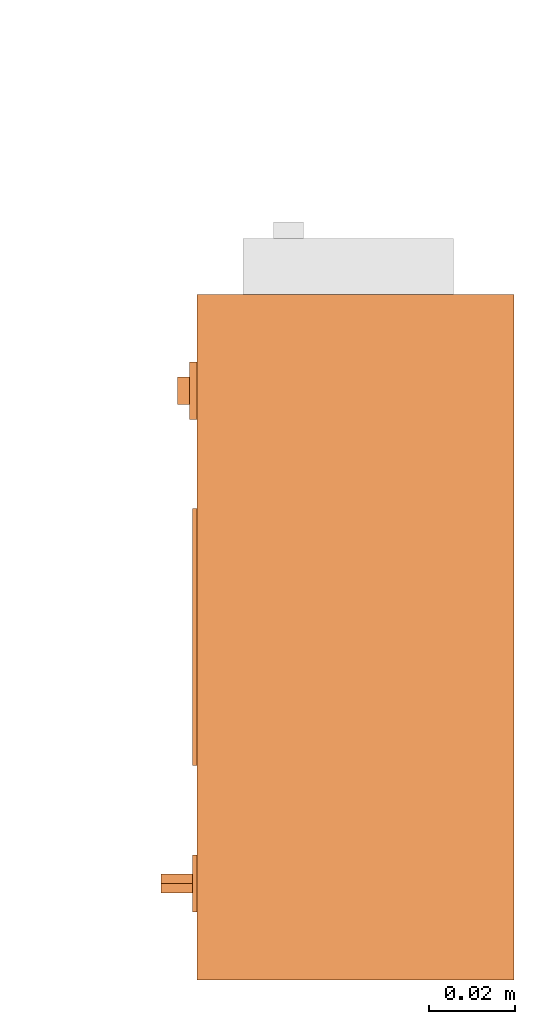
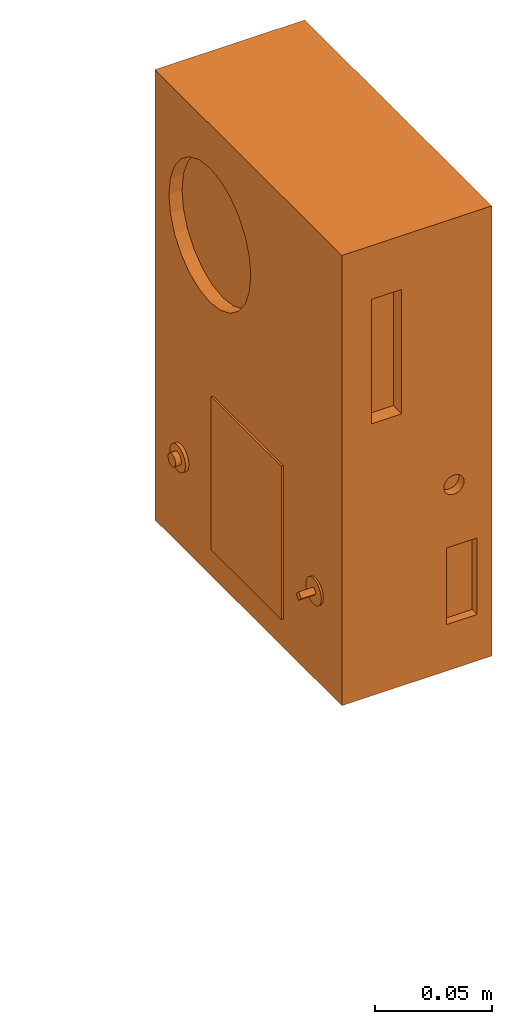
# One storey, part 2 of 4: 1 proxy.
"""IFC2X3 building model written with IfcOpenShell, lengths in millimetres."""

from ifc_helpers import new_model, entity, si_unit, converted_unit, derived_unit, direction, frame, origin, place, context, subcontext, project, spatial, faceted_brep, source, transform, mapped, material, material_list, type_object, type_shapes, element, save


model = new_model("IFC2X3")

# Units and contexts
model_context = context("Model", 3, precision=0.01, world=origin(), true_north=direction((6.12303176911189e-17, 1.0)))
body_context = subcontext(model_context, "Body", "Model", "MODEL_VIEW")
ifc_project = project(units=[si_unit("LENGTHUNIT", "METRE", prefix="MILLI"), si_unit("AREAUNIT", "SQUARE_METRE"), si_unit("VOLUMEUNIT", "CUBIC_METRE"), converted_unit("PLANEANGLEUNIT", "DEGREE", entity("IfcRatioMeasure", 0.0174532925199433), si_unit("PLANEANGLEUNIT", "RADIAN"), dimensions=[0, 0, 0, 0, 0, 0, 0]), si_unit("MASSUNIT", "GRAM", prefix="KILO"), derived_unit("MASSDENSITYUNIT", [(si_unit("MASSUNIT", "GRAM", prefix="KILO"), 1), (si_unit("LENGTHUNIT", "METRE"), -3)]), derived_unit("MOMENTOFINERTIAUNIT", [(si_unit("LENGTHUNIT", "METRE"), 4)]), si_unit("TIMEUNIT", "SECOND"), si_unit("FREQUENCYUNIT", "HERTZ"), si_unit("THERMODYNAMICTEMPERATUREUNIT", "DEGREE_CELSIUS"), derived_unit("THERMALTRANSMITTANCEUNIT", [(si_unit("MASSUNIT", "GRAM", prefix="KILO"), 1), (si_unit("THERMODYNAMICTEMPERATUREUNIT", "KELVIN"), -1), (si_unit("TIMEUNIT", "SECOND"), -3)]), derived_unit("VOLUMETRICFLOWRATEUNIT", [(si_unit("LENGTHUNIT", "METRE"), 3), (si_unit("TIMEUNIT", "SECOND"), -1)]), derived_unit("MASSFLOWRATEUNIT", [(si_unit("MASSUNIT", "GRAM", prefix="KILO"), 1), (si_unit("TIMEUNIT", "SECOND"), -1)]), derived_unit("ROTATIONALFREQUENCYUNIT", [(si_unit("TIMEUNIT", "SECOND"), -1)]), si_unit("ELECTRICCURRENTUNIT", "AMPERE"), si_unit("ELECTRICVOLTAGEUNIT", "VOLT"), si_unit("POWERUNIT", "WATT"), si_unit("FORCEUNIT", "NEWTON", prefix="KILO"), si_unit("ILLUMINANCEUNIT", "LUX"), si_unit("LUMINOUSFLUXUNIT", "LUMEN"), si_unit("LUMINOUSINTENSITYUNIT", "CANDELA"), derived_unit("USERDEFINED", [(si_unit("MASSUNIT", "GRAM", prefix="KILO"), -1), (si_unit("LENGTHUNIT", "METRE"), -2), (si_unit("TIMEUNIT", "SECOND"), 3), (si_unit("LUMINOUSFLUXUNIT", "LUMEN"), 1)]), derived_unit("LINEARVELOCITYUNIT", [(si_unit("LENGTHUNIT", "METRE"), 1), (si_unit("TIMEUNIT", "SECOND"), -1)]), si_unit("PRESSUREUNIT", "PASCAL"), derived_unit("USERDEFINED", [(si_unit("LENGTHUNIT", "METRE"), -2), (si_unit("MASSUNIT", "GRAM", prefix="KILO"), 1), (si_unit("TIMEUNIT", "SECOND"), -2)]), derived_unit("LINEARFORCEUNIT", [(si_unit("MASSUNIT", "GRAM", prefix="KILO"), 1), (si_unit("LENGTHUNIT", "METRE"), 1), (si_unit("TIMEUNIT", "SECOND"), -2), (si_unit("LENGTHUNIT", "METRE"), -1)]), derived_unit("PLANARFORCEUNIT", [(si_unit("MASSUNIT", "GRAM", prefix="KILO"), 1), (si_unit("LENGTHUNIT", "METRE"), 1), (si_unit("TIMEUNIT", "SECOND"), -2), (si_unit("LENGTHUNIT", "METRE"), -2)])], contexts=[model_context])

# Site, building, storey
site_placement = place(None, frame((0.0, 2493.83037508239, 0.0)))
site = spatial("IfcSite", under=ifc_project, at=site_placement, CompositionType="ELEMENT")
building_placement = place(site_placement, origin())
building = spatial("IfcBuilding", under=site, at=building_placement, CompositionType="ELEMENT")
storey_placement = place(building_placement, frame((0.0, 0.0, 24000.0)))
storey = spatial("IfcBuildingStorey", under=building, at=storey_placement, CompositionType="ELEMENT", Elevation=24000.0)

# Proxy
ifc_material_1 = material()
ifc_material_2 = material()
ifc_material_list = material_list([ifc_material_1, ifc_material_2])
building_element_proxy_type = type_object("IfcBuildingElementProxyType", PredefinedType="NOTDEFINED", material=ifc_material_1)
shared_shape = source(origin(), body_context, "Body", "Brep", [
    faceted_brep([(-82.3504485835914, -57.4951122884829, 44.240131361728), (-82.3504485835914, -59.713005625247, 46.4580246984921), (-82.3504485835914, -57.4951122884829, 48.6759180352563), (-82.3504485835914, -55.2772189517187, 46.4580246984921), (-74.0, -55.2772189517187, 46.4580246984921), (-74.0, -57.4951122884829, 48.6759180352563), (-74.0, -59.713005625247, 46.4580246984921), (-74.0, -57.4951122884829, 44.240131361728)], [[[0, 1, 2, 3]], [[4, 5, 6, 7]], [[3, 4, 7, 0]], [[7, 6, 1, 0]], [[1, 6, 5, 2]], [[5, 4, 3, 2]]]),
    faceted_brep([(-78.5701040447422, 54.3886959944422, 45.6256629611489), (-78.5701040447422, 54.2791134928247, 46.4580246984921), (-78.5701040447422, 54.3886959944422, 47.2903864358354), (-78.5701040447422, 54.7099756329028, 48.0660240963215), (-78.5701040447422, 55.2210577317854, 48.7320792551901), (-78.5701040447422, 55.8871128906541, 49.2431613540727), (-78.5701040447422, 56.6627505511402, 49.5644409925334), (-78.5701040447422, 57.4951122884834, 49.6740234941508), (-78.5701040447422, 58.3274740258266, 49.5644409925334), (-78.5701040447422, 59.1031116863127, 49.2431613540727), (-78.5701040447422, 59.7691668451814, 48.7320792551902), (-78.5701040447422, 60.280248944064, 48.0660240963215), (-78.5701040447422, 60.6015285825246, 47.2903864358354), (-78.5701040447422, 60.7111110841421, 46.4580246984921), (-78.5701040447422, 60.6015285825247, 45.6256629611489), (-78.5701040447422, 60.280248944064, 44.8500253006628), (-78.5701040447422, 59.7691668451814, 44.1839701417941), (-78.5701040447422, 59.1031116863128, 43.6728880429116), (-78.5701040447422, 58.3274740258267, 43.3516084044509), (-78.5701040447422, 57.4951122884834, 43.2420259028335), (-78.5701040447422, 56.6627505511402, 43.3516084044509), (-78.5701040447422, 55.8871128906541, 43.6728880429116), (-78.5701040447422, 55.2210577317854, 44.1839701417941), (-78.5701040447422, 54.7099756329029, 44.8500253006628), (-74.0, 57.4951122884834, 49.6740234941508), (-74.0, 56.6627505511402, 49.5644409925334), (-74.0, 55.8871128906541, 49.2431613540727), (-74.0, 55.2210577317854, 48.7320792551901), (-74.0, 54.7099756329028, 48.0660240963215), (-74.0, 54.3886959944422, 47.2903864358354), (-74.0, 54.2791134928247, 46.4580246984921), (-74.0, 54.3886959944422, 45.6256629611489), (-74.0, 54.7099756329028, 44.8500253006628), (-74.0, 55.2210577317854, 44.1839701417941), (-74.0, 55.8871128906541, 43.6728880429116), (-74.0, 56.6627505511402, 43.3516084044509), (-74.0, 57.4951122884834, 43.2420259028335), (-74.0, 58.3274740258266, 43.3516084044509), (-74.0, 59.1031116863127, 43.6728880429116), (-74.0, 59.7691668451814, 44.1839701417941), (-74.0, 60.280248944064, 44.8500253006628), (-74.0, 60.6015285825246, 45.6256629611489), (-74.0, 60.7111110841421, 46.4580246984921), (-74.0, 60.6015285825246, 47.2903864358354), (-74.0, 60.280248944064, 48.0660240963215), (-74.0, 59.7691668451814, 48.7320792551902), (-74.0, 59.1031116863127, 49.2431613540727), (-74.0, 58.3274740258266, 49.5644409925334)], [[[0, 1, 2, 3, 4, 5, 6, 7, 8, 9, 10, 11, 12, 13, 14, 15, 16, 17, 18, 19, 20, 21, 22, 23]], [[24, 25, 26, 27, 28, 29, 30, 31, 32, 33, 34, 35, 36, 37, 38, 39, 40, 41, 42, 43, 44, 45, 46, 47]], [[41, 14, 13, 42]], [[40, 15, 14, 41]], [[17, 16, 39, 38]], [[40, 39, 16, 15]], [[18, 17, 38, 37]], [[19, 18, 37, 36]], [[35, 20, 19, 36]], [[34, 21, 20, 35]], [[23, 22, 33, 32]], [[34, 33, 22, 21]], [[0, 23, 32, 31]], [[1, 0, 31, 30]], [[29, 2, 1, 30]], [[28, 3, 2, 29]], [[5, 4, 27, 26]], [[28, 27, 4, 3]], [[6, 5, 26, 25]], [[7, 6, 25, 24]], [[47, 8, 7, 24]], [[46, 9, 8, 47]], [[11, 10, 45, 44]], [[46, 45, 10, 9]], [[12, 11, 44, 43]], [[13, 12, 43, 42]]]),
    faceted_brep([(-75.0, -54.1636284675258, 52.2283239409835), (-75.0, -52.7836826860589, 51.1694543009162), (-75.0, -51.7248130459916, 49.7895085194492), (-75.0, -51.0591797634297, 48.1825276211214), (-75.0, -50.8321446465688, 46.4580246984921), (-75.0, -51.0591797634297, 44.7335217758629), (-75.0, -51.7248130459915, 43.1265408775351), (-75.0, -52.7836826860589, 41.7465950960681), (-75.0, -54.1636284675258, 40.6877254560008), (-75.0, -55.7706093658536, 40.022092173439), (-75.0, -57.4951122884828, 39.7950570565781), (-75.0, -59.219615211112, 40.0220921734389), (-75.0, -60.8265961094399, 40.6877254560008), (-75.0, -62.2065418909068, 41.7465950960681), (-75.0, -63.2654115309741, 43.1265408775351), (-75.0, -63.931044813536, 44.7335217758629), (-75.0, -64.1580799303969, 46.4580246984921), (-75.0, -63.931044813536, 48.1825276211213), (-75.0, -63.2654115309741, 49.7895085194492), (-75.0, -62.2065418909069, 51.1694543009161), (-75.0, -60.8265961094399, 52.2283239409834), (-75.0, -59.2196152111121, 52.8939572235453), (-75.0, -57.4951122884829, 53.1209923404062), (-75.0, -55.7706093658537, 52.8939572235453), (-74.0, -55.7706093658536, 40.022092173439), (-74.0, -54.1636284675258, 40.6877254560008), (-74.0, -52.7836826860589, 41.7465950960681), (-74.0, -51.7248130459915, 43.1265408775351), (-74.0, -51.0591797634297, 44.7335217758629), (-74.0, -50.8321446465688, 46.4580246984922), (-74.0, -51.0591797634297, 48.1825276211214), (-74.0, -51.7248130459916, 49.7895085194492), (-74.0, -52.7836826860589, 51.1694543009162), (-74.0, -54.1636284675258, 52.2283239409835), (-74.0, -55.7706093658537, 52.8939572235453), (-74.0, -57.4951122884829, 53.1209923404062), (-74.0, -59.2196152111121, 52.8939572235453), (-74.0, -60.8265961094399, 52.2283239409834), (-74.0, -62.2065418909069, 51.1694543009161), (-74.0, -63.2654115309741, 49.7895085194492), (-74.0, -63.931044813536, 48.1825276211213), (-74.0, -64.1580799303969, 46.4580246984921), (-74.0, -63.931044813536, 44.7335217758629), (-74.0, -63.2654115309741, 43.1265408775351), (-74.0, -62.2065418909068, 41.7465950960681), (-74.0, -60.8265961094399, 40.6877254560008), (-74.0, -59.219615211112, 40.0220921734389), (-74.0, -57.4951122884828, 39.7950570565781)], [[[0, 1, 2, 3, 4, 5, 6, 7, 8, 9, 10, 11, 12, 13, 14, 15, 16, 17, 18, 19, 20, 21, 22, 23]], [[24, 25, 26, 27, 28, 29, 30, 31, 32, 33, 34, 35, 36, 37, 38, 39, 40, 41, 42, 43, 44, 45, 46, 47]], [[28, 5, 4, 29]], [[27, 6, 5, 28]], [[8, 7, 26, 25]], [[27, 26, 7, 6]], [[9, 8, 25, 24]], [[10, 9, 24, 47]], [[46, 11, 10, 47]], [[45, 12, 11, 46]], [[14, 13, 44, 43]], [[45, 44, 13, 12]], [[15, 14, 43, 42]], [[16, 15, 42, 41]], [[17, 16, 41, 40]], [[39, 18, 17, 40]], [[20, 19, 38, 37]], [[39, 38, 19, 18]], [[37, 36, 21, 20]], [[22, 21, 36, 35]], [[34, 23, 22, 35]], [[33, 0, 23, 34]], [[2, 1, 32, 31]], [[32, 1, 0, 33]], [[30, 3, 2, 31]], [[4, 3, 30, 29]]]),
    faceted_brep([(-75.7053616894587, 54.1636284675264, 40.6877254560008), (-75.7053616894587, 52.7836826860594, 41.7465950960681), (-75.7053616894587, 51.7248130459921, 43.1265408775351), (-75.7053616894587, 51.0591797634302, 44.7335217758629), (-75.7053616894587, 50.8321446465693, 46.4580246984921), (-75.7053616894587, 51.0591797634302, 48.1825276211213), (-75.7053616894587, 51.7248130459921, 49.7895085194492), (-75.7053616894587, 52.7836826860594, 51.1694543009161), (-75.7053616894587, 54.1636284675264, 52.2283239409834), (-75.7053616894587, 55.7706093658542, 52.8939572235453), (-75.7053616894587, 57.4951122884834, 53.1209923404062), (-75.7053616894587, 59.2196152111126, 52.8939572235453), (-75.7053616894587, 60.8265961094404, 52.2283239409834), (-75.7053616894587, 62.2065418909074, 51.1694543009161), (-75.7053616894587, 63.2654115309747, 49.7895085194492), (-75.7053616894587, 63.9310448135366, 48.1825276211214), (-75.7053616894587, 64.1580799303975, 46.4580246984922), (-75.7053616894587, 63.9310448135366, 44.733521775863), (-75.7053616894587, 63.2654115309747, 43.1265408775351), (-75.7053616894587, 62.2065418909074, 41.7465950960682), (-75.7053616894587, 60.8265961094405, 40.6877254560009), (-75.7053616894587, 59.2196152111126, 40.022092173439), (-75.7053616894587, 57.4951122884834, 39.7950570565781), (-75.7053616894587, 55.7706093658542, 40.0220921734389), (-74.0, 55.7706093658542, 52.8939572235453), (-74.0, 54.1636284675264, 52.2283239409834), (-74.0, 52.7836826860594, 51.1694543009161), (-74.0, 51.7248130459921, 49.7895085194492), (-74.0, 51.0591797634302, 48.1825276211213), (-74.0, 50.8321446465693, 46.4580246984921), (-74.0, 51.0591797634302, 44.7335217758629), (-74.0, 51.7248130459921, 43.1265408775351), (-74.0, 52.7836826860594, 41.7465950960681), (-74.0, 54.1636284675264, 40.6877254560008), (-74.0, 55.7706093658542, 40.0220921734389), (-74.0, 57.4951122884834, 39.7950570565781), (-74.0, 59.2196152111126, 40.022092173439), (-74.0, 60.8265961094405, 40.6877254560009), (-74.0, 62.2065418909074, 41.7465950960682), (-74.0, 63.2654115309747, 43.1265408775351), (-74.0, 63.9310448135366, 44.733521775863), (-74.0, 64.1580799303975, 46.4580246984922), (-74.0, 63.9310448135366, 48.1825276211214), (-74.0, 63.2654115309747, 49.7895085194492), (-74.0, 62.2065418909074, 51.1694543009161), (-74.0, 60.8265961094404, 52.2283239409834), (-74.0, 59.2196152111126, 52.8939572235453), (-74.0, 57.4951122884834, 53.1209923404062)], [[[0, 1, 2, 3, 4, 5, 6, 7, 8, 9, 10, 11, 12, 13, 14, 15, 16, 17, 18, 19, 20, 21, 22, 23]], [[24, 25, 26, 27, 28, 29, 30, 31, 32, 33, 34, 35, 36, 37, 38, 39, 40, 41, 42, 43, 44, 45, 46, 47]], [[17, 16, 41, 40]], [[39, 18, 17, 40]], [[20, 19, 38, 37]], [[39, 38, 19, 18]], [[37, 36, 21, 20]], [[22, 21, 36, 35]], [[34, 23, 22, 35]], [[33, 0, 23, 34]], [[2, 1, 32, 31]], [[32, 1, 0, 33]], [[30, 3, 2, 31]], [[4, 3, 30, 29]], [[28, 5, 4, 29]], [[27, 6, 5, 28]], [[8, 7, 26, 25]], [[27, 26, 7, 6]], [[9, 8, 25, 24]], [[10, 9, 24, 47]], [[46, 11, 10, 47]], [[45, 12, 11, 46]], [[14, 13, 44, 43]], [[45, 44, 13, 12]], [[15, 14, 43, 42]], [[16, 15, 42, 41]]]),
    faceted_brep([(-75.0, 30.0, 95.0), (-75.0, 30.0, 15.0), (-75.0, -30.0, 15.0), (-75.0, -30.0, 95.0), (-74.0, 30.0, 95.0), (-74.0, -30.0, 95.0), (-74.0, -30.0, 15.0), (-74.0, 30.0, 15.0)], [[[0, 1, 2, 3]], [[4, 5, 6, 7]], [[1, 0, 4, 7]], [[2, 1, 7, 6]], [[3, 2, 6, 5]], [[0, 3, 5, 4]]]),
    faceted_brep([(0.0, 80.0, 235.0), (-74.0, 80.0, 235.0), (-74.0, -80.0, 235.0), (0.0, -80.0, 235.0), (0.0, -80.0, 0.0), (-74.0, -80.0, 0.0), (-74.0, 80.0, 0.0), (0.0, 80.0, 0.0), (-74.0, 50.4209133185051, 207.548823548156), (-74.0, 41.9795798970934, 211.045338335818), (-74.0, 57.6696506600342, 201.98667175723), (-74.0, 32.9209133185052, 212.237934415701), (-74.0, 63.2318024509604, 194.737934415701), (-74.0, 66.7283172386224, 186.296600994289), (-74.0, 67.920913318505, 177.237934415701), (-74.0, 23.8622467399169, 211.045338335818), (-74.0, 66.7283172386224, 168.179267837113), (-74.0, 63.2318024509604, 159.737934415701), (-74.0, 57.6696506600342, 152.489197074172), (-74.0, 50.4209133185051, 146.927045283246), (-74.0, 41.9795798970933, 143.430530495584), (-74.0, 32.9209133185051, 142.237934415701), (-74.0, 23.8622467399169, 143.430530495584), (-74.0, -0.886490601612379, 168.179267837113), (-74.0, 2.61002418604972, 159.737934415701), (-74.0, 15.4209133185051, 146.927045283246), (-74.0, 8.17217597697594, 152.489197074172), (-74.0, 15.4209133185051, 207.548823548157), (-74.0, 8.17217597697595, 201.98667175723), (-74.0, 2.61002418604972, 194.737934415701), (-74.0, -0.886490601612362, 186.29660099429), (-74.0, -2.07908668149505, 177.237934415701), (-59.4948410559892, -80.0, 207.012326083588), (-44.4948410559892, -80.0, 207.012326083588), (-59.4948410559892, -80.0, 142.012326083588), (-22.2311731201611, -80.0, 64.2388716266812), (-22.2311731201611, -80.0, 24.2388716266812), (-7.23117312016112, -80.0, 24.2388716266812), (-7.23117312016112, -80.0, 64.2388716266812), (-44.4948410559892, -80.0, 142.012326083588), (-16.1594491359494, -80.0, 100.388904415053), (-15.1239152300166, -80.0, 99.5943113020636), (-14.3293221170272, -80.0, 98.5587773961309), (-13.829820004504, -80.0, 97.3528726216434), (-17.3653539104367, -80.0, 91.2291482646855), (-16.1594491359494, -80.0, 91.7286503772087), (-15.1239152300166, -80.0, 92.5232434901981), (-14.3293221170272, -80.0, 93.5587773961309), (-13.829820004504, -80.0, 94.7646821706183), (-13.6594491359494, -80.0, 96.0587773961309), (-18.6594491359493, -80.0, 91.0587773961309), (-19.9535443614619, -80.0, 91.2291482646855), (-21.1594491359493, -80.0, 91.7286503772087), (-22.1949830418821, -80.0, 92.5232434901981), (-22.9895761548716, -80.0, 93.5587773961308), (-23.4890782673947, -80.0, 94.7646821706182), (-23.6594491359494, -80.0, 96.0587773961309), (-23.4890782673947, -80.0, 97.3528726216435), (-22.9895761548716, -80.0, 98.5587773961309), (-22.1949830418821, -80.0, 99.5943113020636), (-21.1594491359493, -80.0, 100.388904415053), (-19.9535443614619, -80.0, 100.888406527576), (-18.6594491359493, -80.0, 101.058777396131), (-17.3653539104367, -80.0, 100.888406527576), (-67.5070892619463, 15.4209133185049, 207.548823548156), (-67.5070892619462, 23.8622467399167, 211.045338335818), (-67.5070892619462, 32.9209133185049, 212.237934415701), (-67.5070892619462, 41.9795798970931, 211.045338335818), (-67.5070892619462, 50.4209133185049, 207.548823548156), (-67.5070892619462, 57.669650660034, 201.98667175723), (-67.5070892619462, 63.2318024509603, 194.737934415701), (-67.5070892619462, 66.7283172386223, 186.296600994289), (-67.5070892619462, 67.9209133185049, 177.237934415701), (-67.5070892619462, 66.7283172386224, 168.179267837113), (-67.5070892619462, 63.2318024509604, 159.737934415701), (-67.5070892619462, 57.6696506600342, 152.489197074172), (-67.5070892619462, 50.4209133185051, 146.927045283246), (-67.5070892619462, 41.9795798970933, 143.430530495584), (-67.5070892619462, 32.9209133185051, 142.237934415701), (-67.5070892619462, 23.8622467399169, 143.430530495584), (-67.5070892619463, 15.4209133185051, 146.927045283246), (-67.5070892619463, 8.17217597697592, 152.489197074172), (-67.5070892619463, 2.61002418604969, 159.737934415701), (-67.5070892619463, -0.886490601612388, 168.179267837113), (-67.5070892619463, -2.07908668149506, 177.237934415701), (-67.5070892619463, -0.886490601612447, 186.296600994289), (-67.5070892619463, 2.61002418604958, 194.737934415701), (-67.5070892619463, 8.17217597697576, 201.98667175723), (-59.4948410559892, -72.8398650075826, 207.012326083588), (-59.4948410559892, -72.8398650075826, 142.012326083588), (-44.4948410559892, -72.8398650075826, 142.012326083588), (-44.4948410559892, -72.8398650075826, 207.012326083588), (-22.2311731201611, -75.6449854904968, 64.2388716266812), (-22.2311731201611, -75.6449854904968, 24.2388716266812), (-7.23117312016111, -75.6449854904968, 24.2388716266812), (-7.23117312016111, -75.6449854904968, 64.2388716266812), (-21.1594491359494, -75.6449854904968, 91.7286503772087), (-19.953544361462, -75.6449854904968, 91.2291482646855), (-18.6594491359494, -75.6449854904968, 91.0587773961309), (-17.3653539104368, -75.6449854904968, 91.2291482646855), (-16.1594491359494, -75.6449854904968, 91.7286503772087), (-15.1239152300166, -75.6449854904968, 92.5232434901981), (-14.3293221170272, -75.6449854904968, 93.5587773961309), (-13.829820004504, -75.6449854904968, 94.7646821706182), (-13.6594491359493, -75.6449854904968, 96.0587773961308), (-13.829820004504, -75.6449854904968, 97.3528726216434), (-14.3293221170271, -75.6449854904968, 98.5587773961309), (-15.1239152300166, -75.6449854904968, 99.5943113020636), (-16.1594491359493, -75.6449854904968, 100.388904415053), (-17.3653539104367, -75.6449854904968, 100.888406527576), (-18.6594491359493, -75.6449854904968, 101.058777396131), (-19.9535443614619, -75.6449854904968, 100.888406527576), (-21.1594491359493, -75.6449854904968, 100.388904415053), (-22.1949830418821, -75.6449854904968, 99.5943113020636), (-22.9895761548715, -75.6449854904968, 98.5587773961309), (-23.4890782673947, -75.6449854904968, 97.3528726216435), (-23.6594491359494, -75.6449854904968, 96.0587773961309), (-23.4890782673947, -75.6449854904968, 94.7646821706183), (-22.9895761548715, -75.6449854904968, 93.5587773961309), (-22.1949830418821, -75.6449854904968, 92.5232434901981)], [[[0, 1, 2, 3]], [[4, 5, 6, 7]], [[1, 8, 9]], [[8, 1, 10]], [[1, 9, 11]], [[12, 10, 1]], [[13, 12, 1]], [[14, 13, 1]], [[1, 6, 14]], [[15, 1, 11]], [[1, 15, 2]], [[16, 14, 6]], [[17, 16, 6]], [[18, 17, 6]], [[6, 19, 18]], [[19, 6, 20]], [[21, 20, 6]], [[6, 22, 21]], [[22, 6, 5]], [[23, 5, 2]], [[23, 24, 5]], [[25, 22, 5]], [[26, 5, 24]], [[5, 26, 25]], [[2, 15, 27]], [[27, 28, 2]], [[28, 29, 2]], [[29, 30, 2]], [[2, 30, 31]], [[23, 2, 31]], [[2, 32, 33]], [[32, 2, 34]], [[2, 5, 34]], [[2, 33, 3]], [[34, 5, 35]], [[35, 5, 36]], [[5, 4, 36]], [[4, 37, 36]], [[38, 37, 4]], [[38, 4, 3]], [[33, 39, 3]], [[39, 40, 3]], [[40, 41, 3]], [[41, 42, 3]], [[42, 43, 3]], [[3, 43, 38]], [[38, 44, 35]], [[45, 44, 38]], [[45, 38, 46]], [[47, 46, 38]], [[47, 38, 48]], [[49, 48, 38]], [[49, 38, 43]], [[44, 50, 35]], [[35, 50, 51]], [[35, 51, 52]], [[52, 53, 35]], [[54, 35, 53]], [[54, 55, 35]], [[34, 55, 56]], [[55, 34, 35]], [[57, 34, 56]], [[57, 58, 34]], [[58, 59, 39]], [[58, 39, 34]], [[60, 39, 59]], [[39, 60, 61]], [[39, 61, 62]], [[63, 39, 62]], [[39, 63, 40]], [[0, 3, 4, 7]], [[1, 0, 7, 6]], [[64, 65, 66, 67, 68, 69, 70, 71, 72, 73, 74, 75, 76, 77, 78, 79, 80, 81, 82, 83, 84, 85, 86, 87]], [[72, 14, 16, 73]], [[73, 16, 17, 74]], [[76, 75, 18, 19]], [[18, 75, 74, 17]], [[77, 76, 19, 20]], [[77, 20, 21, 78]], [[78, 21, 22, 79]], [[79, 22, 25, 80]], [[82, 81, 26, 24]], [[26, 81, 80, 25]], [[83, 82, 24, 23]], [[83, 23, 31, 84]], [[84, 31, 30, 85]], [[85, 30, 29, 86]], [[64, 87, 28, 27]], [[28, 87, 86, 29]], [[65, 64, 27, 15]], [[65, 15, 11, 66]], [[66, 11, 9, 67]], [[67, 9, 8, 68]], [[70, 69, 10, 12]], [[10, 69, 68, 8]], [[71, 70, 12, 13]], [[71, 13, 14, 72]], [[88, 89, 90, 91]], [[88, 32, 34, 89]], [[90, 89, 34, 39]], [[90, 39, 33, 91]], [[91, 33, 32, 88]], [[92, 93, 94, 95]], [[96, 97, 98, 99, 100, 101, 102, 103, 104, 105, 106, 107, 108, 109, 110, 111, 112, 113, 114, 115, 116, 117, 118, 119]], [[92, 35, 36, 93]], [[93, 36, 37, 94]], [[94, 37, 38, 95]], [[95, 38, 35, 92]], [[104, 49, 43, 105]], [[105, 43, 42, 106]], [[108, 107, 41, 40]], [[41, 107, 106, 42]], [[109, 108, 40, 63]], [[109, 63, 62, 110]], [[110, 62, 61, 111]], [[111, 61, 60, 112]], [[114, 113, 59, 58]], [[59, 113, 112, 60]], [[115, 114, 58, 57]], [[115, 57, 56, 116]], [[116, 56, 55, 117]], [[117, 55, 54, 118]], [[96, 119, 53, 52]], [[53, 119, 118, 54]], [[97, 96, 52, 51]], [[97, 51, 50, 98]], [[98, 50, 44, 99]], [[99, 44, 45, 100]], [[102, 101, 46, 47]], [[46, 101, 100, 45]], [[103, 102, 47, 48]], [[103, 48, 49, 104]]]),
])
type_shapes(building_element_proxy_type, [shared_shape])
proxy_placement = place(storey_placement, frame((71069.9994506841, 12118.347024533, 2560.0)))
element("IfcBuildingElementProxy", 1, at=proxy_placement, inside=storey, type_object=building_element_proxy_type, material=ifc_material_list, context=body_context, shape_type="MappedRepresentation", body=[
    mapped(shared_shape, transform((0.0, 0.0, 0.0), scale=1.0)),
])

save(model, "model.ifc")
